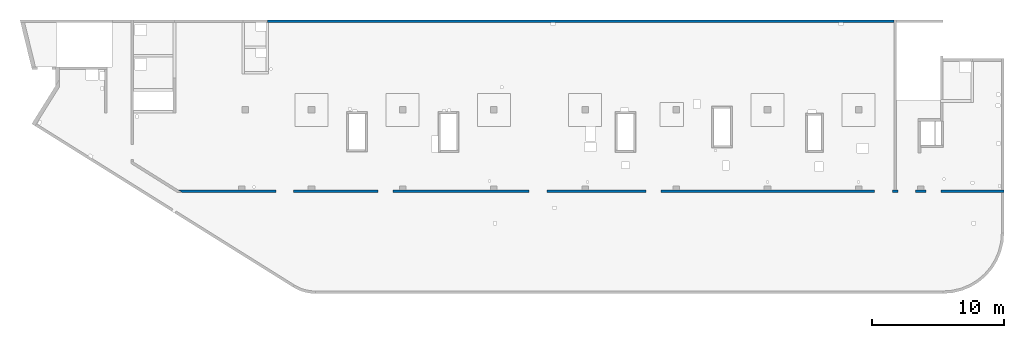
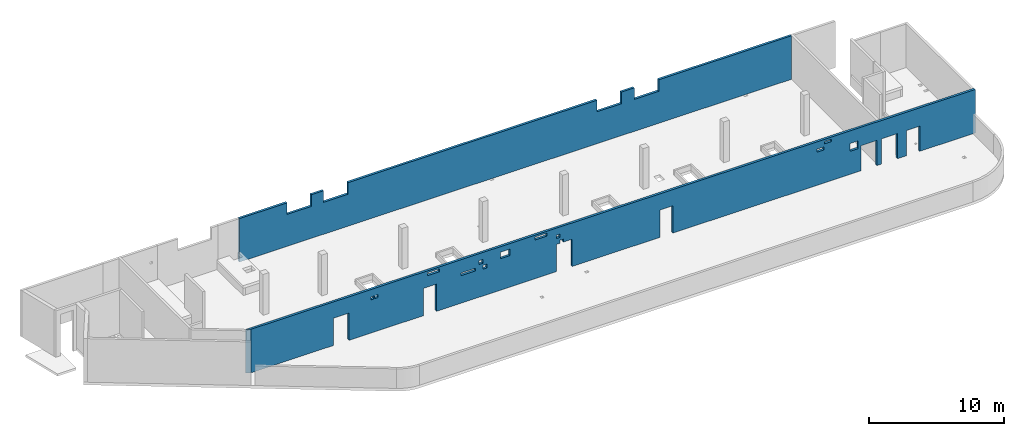
# One storey, part 5 of 6: 2 walls, 24 openings.
"""IFC4 building model written with IfcOpenShell, lengths in millimetres."""

from ifc_helpers import new_model, entity, si_unit, converted_unit, derived_unit, direction, frame, origin, place, context, subcontext, project, spatial, indexed_curve, outline, extrude, polygons, material, type_object, element, save


model = new_model("IFC4")

# Units and contexts
model_context = context("Model", 3, precision=0.01, world=origin(), true_north=direction((6.12303176911189e-17, 1.0)))
plan_context = context("Plan", 3, precision=0.01, world=origin(), true_north=direction((6.12303176911189e-17, 1.0)))
body_context = subcontext(model_context, "Body", "Model", "MODEL_VIEW")
ifc_project = project(units=[si_unit("LENGTHUNIT", "METRE", prefix="MILLI"), si_unit("AREAUNIT", "SQUARE_METRE"), si_unit("VOLUMEUNIT", "CUBIC_METRE"), converted_unit("PLANEANGLEUNIT", "DEGREE", entity("IfcRatioMeasure", 0.0174532925199433), si_unit("PLANEANGLEUNIT", "RADIAN"), dimensions=[0, 0, 0, 0, 0, 0, 0]), si_unit("MASSUNIT", "GRAM", prefix="KILO"), derived_unit("MASSDENSITYUNIT", [(si_unit("MASSUNIT", "GRAM", prefix="KILO"), 1), (si_unit("LENGTHUNIT", "METRE"), -3)]), derived_unit("MOMENTOFINERTIAUNIT", [(si_unit("LENGTHUNIT", "METRE"), 4)]), si_unit("TIMEUNIT", "SECOND"), si_unit("FREQUENCYUNIT", "HERTZ"), si_unit("THERMODYNAMICTEMPERATUREUNIT", "DEGREE_CELSIUS"), derived_unit("THERMALTRANSMITTANCEUNIT", [(si_unit("MASSUNIT", "GRAM", prefix="KILO"), 1), (si_unit("THERMODYNAMICTEMPERATUREUNIT", "KELVIN"), -1), (si_unit("TIMEUNIT", "SECOND"), -3)]), derived_unit("VOLUMETRICFLOWRATEUNIT", [(si_unit("LENGTHUNIT", "METRE"), 3), (si_unit("TIMEUNIT", "SECOND"), -1)]), derived_unit("MASSFLOWRATEUNIT", [(si_unit("MASSUNIT", "GRAM", prefix="KILO"), 1), (si_unit("TIMEUNIT", "SECOND"), -1)]), derived_unit("ROTATIONALFREQUENCYUNIT", [(si_unit("TIMEUNIT", "SECOND"), -1)]), si_unit("ELECTRICCURRENTUNIT", "AMPERE"), si_unit("ELECTRICVOLTAGEUNIT", "VOLT"), si_unit("POWERUNIT", "WATT"), si_unit("FORCEUNIT", "NEWTON", prefix="KILO"), si_unit("ILLUMINANCEUNIT", "LUX"), si_unit("LUMINOUSFLUXUNIT", "LUMEN"), si_unit("LUMINOUSINTENSITYUNIT", "CANDELA"), derived_unit("USERDEFINED", [(si_unit("MASSUNIT", "GRAM", prefix="KILO"), -1), (si_unit("LENGTHUNIT", "METRE"), -2), (si_unit("TIMEUNIT", "SECOND"), 3), (si_unit("LUMINOUSFLUXUNIT", "LUMEN"), 1)]), derived_unit("LINEARVELOCITYUNIT", [(si_unit("LENGTHUNIT", "METRE"), 1), (si_unit("TIMEUNIT", "SECOND"), -1)]), si_unit("PRESSUREUNIT", "PASCAL"), derived_unit("USERDEFINED", [(si_unit("LENGTHUNIT", "METRE"), -2), (si_unit("MASSUNIT", "GRAM", prefix="KILO"), 1), (si_unit("TIMEUNIT", "SECOND"), -2)]), derived_unit("LINEARFORCEUNIT", [(si_unit("MASSUNIT", "GRAM", prefix="KILO"), 1), (si_unit("LENGTHUNIT", "METRE"), 1), (si_unit("TIMEUNIT", "SECOND"), -2), (si_unit("LENGTHUNIT", "METRE"), -1)]), derived_unit("PLANARFORCEUNIT", [(si_unit("MASSUNIT", "GRAM", prefix="KILO"), 1), (si_unit("LENGTHUNIT", "METRE"), 1), (si_unit("TIMEUNIT", "SECOND"), -2), (si_unit("LENGTHUNIT", "METRE"), -2)])], contexts=[model_context, plan_context])

# Site, building, storey
site_placement = place(None, origin())
site = spatial("IfcSite", under=ifc_project, at=site_placement, CompositionType="ELEMENT")
building_placement = place(site_placement, origin())
building = spatial("IfcBuilding", under=site, at=building_placement, CompositionType="ELEMENT")
storey_placement = place(building_placement, frame((0.0, 0.0, 28200.0)))
storey = spatial("IfcBuildingStorey", under=building, at=storey_placement, Name="08", CompositionType="ELEMENT", Elevation=28200.0)

# Wall, openings
ifc_material = material()
wall_type = type_object("IfcWallType", Name=":ADSK_ 25_200", PredefinedType="STANDARD")
wall_1_placement = place(storey_placement, frame((11060.82, 7550.0, -150.0)))
wall_1 = element("IfcWall", 1, at=wall_1_placement, inside=storey, type_object=wall_type, material=ifc_material, Name=":ADSK_ 25_200", ObjectType=":ADSK_ 25_200", PredefinedType="NOTDEFINED", context=body_context, shape_type="Tessellation", body=[
    polygons([(62509.1817957401, -99.9999999999989, 3950.0), (320.073152365613, -100.0, 3950.0), (320.073152365616, -100.0, 0.0), (7409.18261361114, -99.9999999999989, 0.0), (7409.18261361114, -99.9999999999989, 2479.99999999805), (8759.18261361114, -99.9999999999989, 2479.99999999804), (8759.18261361114, -100.000000000001, 0.0), (15129.1826136111, -100.0, 0.0), (15129.1826136111, -100.0, 2479.99999999805), (16259.1826136111, -100.0, 2479.99999999804), (16259.1826136111, -100.0, 0.0), (26559.1826136111, -100.0, 0.0), (26559.1826136111, -100.0, 2479.99999999805), (26859.1826136111, -99.9999999999989, 2479.99999999805), (26859.1826136111, -100.000000000322, 2749.99999999994), (27159.1826136111, -100.000000000321, 2749.99999999994), (27159.1826136111, -100.0, 2479.99999999805), (27909.1826136111, -100.0, 2479.99999999804), (27909.1826136111, -100.0, 0.0), (35429.1826136111, -100.0, 0.0), (35429.1826136111, -100.0, 2479.99999999805), (36559.1826136111, -100.000000000001, 2479.99999999804), (36559.1826136111, -100.000000000001, 0.0), (52719.1826136111, -100.0, 0.0), (52719.1826136111, -100.0, 2279.99999999804), (54069.1826136111, -100.0, 2279.99999999804), (54069.1826136111, -100.0, 0.0), (54469.1826136111, -100.000000000001, 0.0), (54469.1826136111, -99.9999999999989, 2279.99999999804), (55819.1826136111, -100.000000000001, 2279.99999999804), (55819.1826136111, -100.000000000001, 0.0), (56619.1826136111, -100.0, 0.0), (56619.1826136111, -100.0, 2279.99999999804), (57749.1826136111, -100.0, 2279.99999999804), (57749.1826136111, -100.0, 0.0), (62309.1817957401, -100.0, 0.0), (62509.1817957401, -99.9999999999989, 0.0), (62509.1817957401, -100.0, 1770.0), (51759.1826136112, -100.000000000321, 2800.0), (52459.1826136112, -100.000000000321, 2800.0), (52459.1826136112, -100.000000000321, 2100.00000000002), (51759.1826136112, -100.000000000321, 2100.00000000002), (49569.1826136112, -100.000000000321, 3755.0), (50169.1826136112, -100.000000000322, 3755.0), (50169.1826136112, -100.000000000322, 3540.00000000001), (49569.1826136112, -100.000000000321, 3540.00000000001), (48924.1826136112, -100.000000000319, 3284.99999999999), (49524.1826136112, -100.000000000321, 3284.99999999999), (49524.1826136112, -100.000000000321, 3010.0), (48924.1826136112, -100.000000000319, 3010.0), (24729.1826136111, -100.000000000321, 3784.99999999994), (25729.1826136111, -100.000000000321, 3784.99999999994), (25729.1826136111, -100.000000000321, 3509.99999999995), (24729.1826136111, -100.000000000321, 3509.99999999995), (26559.1826136111, -100.000000000321, 3299.99999999994), (26859.1826136111, -100.000000000319, 3299.99999999994), (26859.1826136111, -100.000000000319, 2999.99999999995), (26559.1826136111, -100.000000000321, 2999.99999999995), (21774.1826136111, -100.000000000322, 3450.0), (22574.1826136111, -100.000000000322, 3450.0), (22574.1826136111, -100.000000000322, 2850.00000000001), (21774.1826136111, -100.000000000322, 2850.00000000001), (18359.1826136111, -100.000000000319, 2749.99999999998), (19609.1826136111, -100.000000000321, 2749.99999999998), (19609.1826136111, -100.000000000321, 2500.0), (18359.1826136111, -100.000000000319, 2500.0), (19904.1826136112, -100.000000000319, 3319.99999999999), (20254.1826136111, -100.000000000321, 3319.99999999999), (20254.1826136111, -100.000000000321, 2970.0), (19904.1826136112, -100.000000000319, 2970.0), (20254.1826136111, -100.000000000321, 2779.99999999998), (20604.1826136111, -100.000000000321, 2779.99999999998), (20604.1826136111, -100.000000000321, 2430.0), (20254.1826136111, -100.000000000321, 2430.0), (15504.1826136112, -100.000000000321, 3784.99999999997), (16504.1826136112, -100.000000000321, 3784.99999999997), (16504.1826136112, -100.000000000321, 3509.99999999998), (15504.1826136112, -100.000000000321, 3509.99999999998), (10624.1826136112, -100.000000000321, 3284.99999999995), (10899.1826136112, -100.000000000321, 3284.99999999995), (10899.1826136112, -100.000000000321, 3009.99999999997), (10624.1826136112, -100.000000000321, 3009.99999999997), (10974.1826136112, -100.000000000321, 3284.99999999995), (11249.1826136112, -100.000000000319, 3284.99999999995), (11249.1826136112, -100.000000000319, 3009.99999999997), (10974.1826136112, -100.000000000321, 3009.99999999997), (1.91187300746924e-12, 100.000000000001, 3950.0), (54169.1826136112, 100.0, 3950.0), (54369.1826136112, 100.0, 3950.0), (62309.1817957401, 100.0, 3950.0), (62509.1817957401, 100.0, 3950.0), (62509.1817957401, 100.0, 0.0), (62309.1817957401, 100.0, 0.0), (57749.1826136111, 100.000000000001, 0.0), (57749.1826136111, 100.000000000001, 2279.99999999804), (56619.1826136111, 100.0, 2279.99999999804), (56619.1826136111, 100.0, 0.0), (56459.1826136112, 100.0, 0.0), (55959.1826136112, 100.0, 0.0), (55819.1826136111, 100.0, 0.0), (55819.1826136111, 100.0, 2279.99999999804), (54469.1826136111, 100.0, 2279.99999999804), (54469.1826136111, 100.0, 0.0), (54369.1826136112, 100.0, 0.0), (54169.1826136112, 100.0, 0.0), (54069.1826136111, 100.0, 0.0), (54069.1826136111, 100.0, 2279.99999999804), (52719.1826136111, 100.0, 2279.99999999804), (52719.1826136111, 99.9999999999989, 0.0), (51759.1826136112, 100.0, 0.0), (51259.1826136112, 100.0, 0.0), (44859.1826136112, 100.000000000001, 0.0), (44359.1826136112, 100.0, 0.0), (37959.1826136112, 100.0, 0.0), (37459.1826136112, 100.0, 0.0), (36559.1826136111, 100.0, 0.0), (36559.1826136111, 100.0, 2479.99999999805), (35429.1826136111, 100.0, 2479.99999999805), (35429.1826136111, 100.0, 0.0), (31059.1826136112, 100.0, 0.0), (30559.1826136112, 100.0, 0.0), (27909.1826136111, 100.0, 0.0), (27909.1826136111, 100.0, 2479.99999999805), (27159.1826136111, 100.0, 2479.99999999805), (27159.1826136111, 100.0, 2749.99999999994), (26859.1826136111, 100.0, 2749.99999999994), (26859.1826136111, 100.0, 2479.99999999805), (26559.1826136111, 100.0, 2479.99999999805), (26559.1826136111, 100.0, 0.0), (24159.1826136112, 100.0, 0.0), (23659.1826136112, 100.0, 0.0), (17259.1826136112, 100.0, 0.0), (16759.1826136112, 100.0, 0.0), (16259.1826136111, 100.0, 0.0), (16259.1826136111, 100.0, 2479.99999999805), (15129.1826136111, 99.9999999999989, 2479.99999999805), (15129.1826136111, 99.9999999999989, 0.0), (10359.1826136112, 100.0, 0.0), (9859.18261361118, 100.0, 0.0), (8759.18261361114, 100.0, 0.0), (8759.18261361114, 100.0, 2479.99999999805), (7409.18261361114, 100.0, 2479.99999999805), (7409.18261361115, 100.0, 0.0), (5089.18186898228, 100.0, 0.0), (4589.18186898228, 100.0, 0.0), (-2.53861251127542e-13, 100.000000000001, 0.0), (52459.1826136112, 100.0, 2800.0), (51759.1826136112, 100.0, 2800.0), (51759.1826136112, 100.0, 2100.00000000002), (52459.1826136112, 100.0, 2100.00000000002), (50169.1826136112, 100.0, 3755.0), (49569.1826136112, 100.000000000001, 3755.0), (49569.1826136112, 100.000000000001, 3540.00000000001), (50169.1826136112, 100.0, 3540.00000000001), (49524.1826136112, 100.000000000001, 3284.99999999999), (48924.1826136112, 100.0, 3284.99999999999), (48924.1826136112, 100.0, 3010.0), (49524.1826136112, 100.000000000001, 3010.0), (25729.1826136111, 100.000000000001, 3784.99999999994), (24729.1826136111, 100.000000000001, 3784.99999999994), (24729.1826136111, 100.000000000001, 3509.99999999995), (25729.1826136111, 100.000000000001, 3509.99999999995), (26859.1826136111, 100.0, 3299.99999999994), (26559.1826136111, 100.0, 3299.99999999994), (26559.1826136111, 100.0, 2999.99999999995), (26859.1826136111, 100.0, 2999.99999999995), (22574.1826136111, 100.0, 3450.0), (21774.1826136111, 100.0, 3450.0), (21774.1826136111, 100.0, 2850.00000000001), (22574.1826136111, 100.0, 2850.00000000001), (19609.1826136111, 100.0, 2749.99999999998), (18359.1826136112, 100.000000000001, 2749.99999999998), (18359.1826136112, 100.000000000001, 2500.0), (19609.1826136111, 100.0, 2500.0), (20254.1826136111, 100.0, 3319.99999999999), (19904.1826136111, 100.0, 3319.99999999999), (19904.1826136111, 100.0, 2970.0), (20254.1826136111, 100.0, 2970.0), (20604.1826136111, 99.9999999999989, 2779.99999999998), (20254.1826136111, 100.000000000001, 2779.99999999998), (20254.1826136111, 100.000000000001, 2430.0), (20604.1826136111, 99.9999999999989, 2430.0), (16504.1826136112, 100.000000000001, 3784.99999999997), (15504.1826136112, 100.0, 3784.99999999997), (15504.1826136112, 100.0, 3509.99999999998), (16504.1826136112, 100.000000000001, 3509.99999999998), (10899.1826136112, 100.000000000001, 3284.99999999995), (10624.1826136112, 100.0, 3284.99999999995), (10624.1826136112, 100.0, 3009.99999999997), (10899.1826136112, 100.000000000001, 3009.99999999997), (11249.1826136112, 100.0, 3284.99999999995), (10974.1826136112, 100.000000000001, 3284.99999999995), (10974.1826136112, 100.000000000001, 3009.99999999997), (11249.1826136112, 100.0, 3009.99999999997)], [[[1, 2, 3, 4, 5, 6, 7, 8, 9, 10, 11, 12, 13, 14, 15, 16, 17, 18, 19, 20, 21, 22, 23, 24, 25, 26, 27, 28, 29, 30, 31, 32, 33, 34, 35, 36, 37, 38], [39, 40, 41, 42], [43, 44, 45, 46], [47, 48, 49, 50], [51, 52, 53, 54], [55, 56, 57, 58], [59, 60, 61, 62], [63, 64, 65, 66], [67, 68, 69, 70], [71, 72, 73, 74], [75, 76, 77, 78], [79, 80, 81, 82], [83, 84, 85, 86]], [[87, 88, 89, 90, 91, 92, 93, 94, 95, 96, 97, 98, 99, 100, 101, 102, 103, 104, 105, 106, 107, 108, 109, 110, 111, 112, 113, 114, 115, 116, 117, 118, 119, 120, 121, 122, 123, 124, 125, 126, 127, 128, 129, 130, 131, 132, 133, 134, 135, 136, 137, 138, 139, 140, 141, 142, 143, 144, 145, 146], [147, 148, 149, 150], [151, 152, 153, 154], [155, 156, 157, 158], [159, 160, 161, 162], [163, 164, 165, 166], [167, 168, 169, 170], [171, 172, 173, 174], [175, 176, 177, 178], [179, 180, 181, 182], [183, 184, 185, 186], [187, 188, 189, 190], [191, 192, 193, 194]], [[3, 146, 145, 144, 143, 4]], [[2, 1, 91, 90, 89, 88, 87]], [[3, 2, 87, 146]], [[37, 92, 91, 1, 38]], [[29, 102, 101, 30]], [[30, 101, 100, 31]], [[102, 29, 28, 103]], [[5, 142, 141, 6]], [[6, 141, 140, 7]], [[142, 5, 4, 143]], [[9, 136, 135, 10]], [[10, 135, 134, 11]], [[136, 9, 8, 137]], [[123, 18, 17, 124]], [[18, 123, 122, 19]], [[128, 13, 12, 129]], [[21, 118, 117, 22]], [[22, 117, 116, 23]], [[118, 21, 20, 119]], [[25, 108, 107, 26]], [[26, 107, 106, 27]], [[108, 25, 24, 109]], [[33, 96, 95, 34]], [[34, 95, 94, 35]], [[96, 33, 32, 97]], [[40, 39, 148, 147]], [[40, 147, 150, 41]], [[41, 150, 149, 42]], [[148, 39, 42, 149]], [[44, 43, 152, 151]], [[44, 151, 154, 45]], [[45, 154, 153, 46]], [[152, 43, 46, 153]], [[48, 47, 156, 155]], [[48, 155, 158, 49]], [[49, 158, 157, 50]], [[156, 47, 50, 157]], [[52, 51, 160, 159]], [[52, 159, 162, 53]], [[53, 162, 161, 54]], [[160, 51, 54, 161]], [[56, 55, 164, 163]], [[56, 163, 166, 57]], [[57, 166, 165, 58]], [[164, 55, 58, 165]], [[125, 16, 15, 126]], [[16, 125, 124, 17]], [[126, 15, 14, 127]], [[60, 59, 168, 167]], [[60, 167, 170, 61]], [[61, 170, 169, 62]], [[168, 59, 62, 169]], [[64, 63, 172, 171]], [[64, 171, 174, 65]], [[65, 174, 173, 66]], [[172, 63, 66, 173]], [[68, 67, 176, 175]], [[68, 175, 178, 69]], [[69, 178, 177, 70]], [[176, 67, 70, 177]], [[179, 72, 71, 180]], [[72, 179, 182, 73]], [[73, 182, 181, 74]], [[180, 71, 74, 181]], [[76, 75, 184, 183]], [[76, 183, 186, 77]], [[77, 186, 185, 78]], [[184, 75, 78, 185]], [[80, 79, 188, 187]], [[80, 187, 190, 81]], [[81, 190, 189, 82]], [[188, 79, 82, 189]], [[84, 83, 192, 191]], [[84, 191, 194, 85]], [[85, 194, 193, 86]], [[192, 83, 86, 193]], [[13, 128, 127, 14]], [[7, 140, 139, 138, 137, 8]], [[11, 134, 133, 132, 131, 130, 129, 12]], [[19, 122, 121, 120, 119, 20]], [[23, 116, 115, 114, 113, 112, 111, 110, 109, 24]], [[27, 106, 105, 104, 103, 28]], [[31, 100, 99, 98, 97, 32]], [[92, 37, 36, 35, 94, 93]]], closed=True),
])
placement_1 = place(wall_1_placement, frame((-11060.82, -7550.0, 150.0)))
element("IfcOpeningElement", 2, at=placement_1, cuts=wall_1, Name=":ADSK_ 25_200", PredefinedType="OPENING", context=body_context, shape_type="SweptSolid", body=[
    extrude(outline(indexed_curve([(-675.000000000003, -1239.99999999902), (674.999999999998, -1239.99999999902), (674.999999999998, 1239.99999999902), (-675.000000000003, 1239.99999999902), (-675.000000000003, -1239.99999999902)], self_intersect=False)), frame((19145.0, 7350.0, 1090.0), z_axis=(0.0, 1.0, 0.0), x_axis=(1.0, 0.0, 0.0)), (0.0, 0.0, 1.0), 400.000000001942),
])
element("IfcOpeningElement", 3, at=placement_1, cuts=wall_1, Name=":ADSK_ 25_200", PredefinedType="OPENING", context=body_context, shape_type="SweptSolid", body=[
    extrude(outline(indexed_curve([(-564.999999999997, -1239.99999999902), (565.000000000001, -1239.99999999902), (565.000000000001, 1239.99999999902), (-564.999999999997, 1239.99999999902), (-564.999999999997, -1239.99999999902)], self_intersect=False)), frame((26755.0, 7350.0, 1090.0), z_axis=(0.0, 1.0, 0.0), x_axis=(1.0, 0.0, 0.0)), (0.0, 0.0, 1.0), 400.000000001942),
])
placement_2 = place(wall_1_placement, frame((-11060.82, -7550.0, -4050.0)))
element("IfcOpeningElement", 4, at=placement_2, cuts=wall_1, Name=":ADSK_ 25_200", PredefinedType="OPENING", context=body_context, shape_type="SweptSolid", body=[
    extrude(outline(indexed_curve([(-675.000000000003, -1239.99999999902), (674.999999999998, -1239.99999999902), (674.999999999998, 1239.99999999902), (-675.000000000003, 1239.99999999902), (-675.000000000003, -1239.99999999902)], self_intersect=False)), frame((38295.0, 7350.0, 5290.0), z_axis=(0.0, 1.0, 0.0), x_axis=(1.0, 0.0, 0.0)), (0.0, 0.0, 1.0), 400.000000001943),
])
element("IfcOpeningElement", 5, at=placement_2, cuts=wall_1, Name=":ADSK_ 25_200", PredefinedType="OPENING", context=body_context, shape_type="SweptSolid", body=[
    extrude(outline(indexed_curve([(-565.000000000001, -1239.99999999902), (565.000000000001, -1239.99999999902), (565.000000000001, 1239.99999999902), (-565.000000000001, 1239.99999999902), (-565.000000000001, -1239.99999999902)], self_intersect=False)), frame((47055.0, 7350.0, 5290.0), z_axis=(0.0, 1.0, 0.0), x_axis=(1.0, 0.0, 0.0)), (0.0, 0.0, 1.0), 400.000000001943),
])
element("IfcOpeningElement", 6, at=placement_1, cuts=wall_1, Name=":ADSK_ 25_200", PredefinedType="OPENING", context=body_context, shape_type="SweptSolid", body=[
    extrude(outline(indexed_curve([(-675.000000000003, -1139.99999999902), (674.999999999994, -1139.99999999902), (674.999999999994, 1139.99999999902), (-675.000000000003, 1139.99999999902), (-675.000000000003, -1139.99999999902)], self_intersect=False)), frame((64455.0, 7350.0, 990.0), z_axis=(0.0, 1.0, 0.0), x_axis=(1.0, 0.0, 0.0)), (0.0, 0.0, 1.0), 400.000000001943),
])
element("IfcOpeningElement", 7, at=placement_1, cuts=wall_1, Name=":ADSK_ 25_200", PredefinedType="OPENING", context=body_context, shape_type="SweptSolid", body=[
    extrude(outline(indexed_curve([(-675.000000000003, -1139.99999999902), (674.999999999994, -1139.99999999902), (674.999999999994, 1139.99999999902), (-675.000000000003, 1139.99999999902), (-675.000000000003, -1139.99999999902)], self_intersect=False)), frame((66205.0, 7350.0, 990.0), z_axis=(0.0, 1.0, 0.0), x_axis=(1.0, 0.0, 0.0)), (0.0, 0.0, 1.0), 400.000000001942),
])
element("IfcOpeningElement", 8, at=placement_2, cuts=wall_1, Name=":ADSK_ 25_200", PredefinedType="OPENING", context=body_context, shape_type="SweptSolid", body=[
    extrude(outline(indexed_curve([(-565.000000000001, -1139.99999999902), (565.000000000001, -1139.99999999902), (565.000000000001, 1139.99999999902), (-565.000000000001, 1139.99999999902), (-565.000000000001, -1139.99999999902)], self_intersect=False)), frame((68245.0, 7350.0, 5190.0), z_axis=(0.0, 1.0, 0.0), x_axis=(1.0, 0.0, 0.0)), (0.0, 0.0, 1.0), 400.000000001942),
])
element("IfcOpeningElement", 9, at=placement_1, cuts=wall_1, Name=":ADSK_ 25_200", PredefinedType="OPENING", context=body_context, shape_type="SweptSolid", body=[
    extrude(outline(indexed_curve([(-150.000000000001, -134.999999999991), (150.000000000001, -134.999999999991), (150.000000000001, 134.999999999995), (-150.000000000001, 134.999999999995), (-150.000000000001, -134.999999999991)], self_intersect=False)), frame((38070.0, 7450.0, 2465.0), z_axis=(0.0, 1.0, 0.0), x_axis=(1.0, 0.0, 0.0)), (0.0, 0.0, 1.0), 200.000000000962),
])
element("IfcOpeningElement", 10, at=placement_1, cuts=wall_1, Name=":ADSK_ 25_200", PredefinedType="OPENING", context=body_context, shape_type="SweptSolid", body=[
    extrude(outline(indexed_curve([(-174.999999999999, -174.999999999991), (174.999999999999, -174.999999999991), (174.999999999999, 174.999999999995), (-174.999999999999, 174.999999999995), (-174.999999999999, -174.999999999991)], self_intersect=False)), frame((31140.0, 7450.0, 2995.0), z_axis=(0.0, 1.0, 0.0), x_axis=(1.0, 0.0, 0.0)), (0.0, 0.0, 1.0), 200.000000000962),
])
element("IfcOpeningElement", 11, at=placement_1, cuts=wall_1, Name=":ADSK_ 25_200", PredefinedType="OPENING", context=body_context, shape_type="SweptSolid", body=[
    extrude(outline(indexed_curve([(-175.000000000004, -174.999999999991), (174.999999999995, -174.999999999991), (174.999999999995, 174.999999999995), (-175.000000000004, 174.999999999995), (-175.000000000004, -174.999999999991)], self_intersect=False)), frame((31490.0, 7450.0, 2455.0), z_axis=(0.0, 1.0, 0.0), x_axis=(1.0, 0.0, 0.0)), (0.0, 0.0, 1.0), 200.000000000962),
])
element("IfcOpeningElement", 12, at=placement_1, cuts=wall_1, Name=":ADSK_ 25_200", PredefinedType="OPENING", context=body_context, shape_type="SweptSolid", body=[
    extrude(outline(indexed_curve([(-150.000000000001, -149.999999999992), (150.000000000001, -149.999999999992), (150.000000000001, 149.999999999992), (-150.000000000001, 149.999999999992), (-150.000000000001, -149.999999999992)], self_intersect=False)), frame((37770.0, 7450.0, 3000.0), z_axis=(0.0, 1.0, 0.0), x_axis=(1.0, 0.0, 0.0)), (0.0, 0.0, 1.0), 200.000000000962),
])
element("IfcOpeningElement", 13, at=placement_1, cuts=wall_1, Name=":ADSK_ 25_200", PredefinedType="OPENING", context=body_context, shape_type="SweptSolid", body=[
    extrude(outline(indexed_curve([(-349.999999999998, -349.999999999994), (349.999999999998, -349.999999999994), (349.999999999998, 349.99999999999), (-349.999999999998, 349.99999999999), (-349.999999999998, -349.999999999994)], self_intersect=False)), frame((63170.0, 7450.0, 2300.0), z_axis=(0.0, 1.0, 0.0), x_axis=(1.0, 0.0, 0.0)), (0.0, 0.0, 1.0), 200.000000000962),
])
element("IfcOpeningElement", 14, at=placement_1, cuts=wall_1, Name=":ADSK_ 25_200", PredefinedType="OPENING", context=body_context, shape_type="SweptSolid", body=[
    extrude(outline(indexed_curve([(-300.000000000001, -107.499999999993), (300.000000000001, -107.499999999993), (300.000000000001, 107.499999999993), (-300.000000000001, 107.499999999993), (-300.000000000001, -107.499999999993)], self_intersect=False)), frame((60930.0, 7450.0, 3497.5), z_axis=(0.0, 1.0, 0.0), x_axis=(1.0, 0.0, 0.0)), (0.0, 0.0, 1.0), 200.000000000962),
])
element("IfcOpeningElement", 15, at=placement_1, cuts=wall_1, Name=":ADSK_ 25_200", PredefinedType="OPENING", context=body_context, shape_type="SweptSolid", body=[
    extrude(outline(indexed_curve([(-300.000000000001, -137.49999999999), (300.000000000001, -137.49999999999), (300.000000000001, 137.499999999995), (-300.000000000001, 137.499999999995), (-300.000000000001, -137.49999999999)], self_intersect=False)), frame((60285.0, 7450.0, 2997.5), z_axis=(0.0, 1.0, 0.0), x_axis=(1.0, 0.0, 0.0)), (0.0, 0.0, 1.0), 200.000000000962),
])
element("IfcOpeningElement", 16, at=placement_1, cuts=wall_1, Name=":ADSK_ 25_200", PredefinedType="OPENING", context=body_context, shape_type="SweptSolid", body=[
    extrude(outline(indexed_curve([(-499.999999999999, -137.499999999995), (499.999999999999, -137.499999999995), (499.999999999999, 137.49999999999), (-499.999999999999, 137.49999999999), (-499.999999999999, -137.499999999995)], self_intersect=False)), frame((36290.0, 7450.0, 3497.5), z_axis=(0.0, 1.0, 0.0), x_axis=(1.0, 0.0, 0.0)), (0.0, 0.0, 1.0), 200.000000000962),
])
element("IfcOpeningElement", 17, at=placement_1, cuts=wall_1, Name=":ADSK_ 25_200", PredefinedType="OPENING", context=body_context, shape_type="SweptSolid", body=[
    extrude(outline(indexed_curve([(-400.0, -299.999999999992), (400.0, -299.999999999992), (400.0, 299.999999999992), (-400.0, 299.999999999992), (-400.0, -299.999999999992)], self_intersect=False)), frame((33235.0, 7450.0, 3000.0), z_axis=(0.0, 1.0, 0.0), x_axis=(1.0, 0.0, 0.0)), (0.0, 0.0, 1.0), 200.000000000962),
])
element("IfcOpeningElement", 18, at=placement_1, cuts=wall_1, Name=":ADSK_ 25_200", PredefinedType="OPENING", context=body_context, shape_type="SweptSolid", body=[
    extrude(outline(indexed_curve([(-625.000000000005, -124.999999999998), (624.999999999996, -124.999999999998), (624.999999999996, 124.999999999989), (-625.000000000005, 124.999999999989), (-625.000000000005, -124.999999999998)], self_intersect=False)), frame((30045.0, 7450.0, 2475.0), z_axis=(0.0, 1.0, 0.0), x_axis=(1.0, 0.0, 0.0)), (0.0, 0.0, 1.0), 200.000000000962),
])
element("IfcOpeningElement", 19, at=placement_1, cuts=wall_1, Name=":ADSK_ 25_200", PredefinedType="OPENING", context=body_context, shape_type="SweptSolid", body=[
    extrude(outline(indexed_curve([(-499.999999999999, -137.49999999999), (499.999999999999, -137.49999999999), (499.999999999999, 137.499999999995), (-499.999999999999, 137.499999999995), (-499.999999999999, -137.49999999999)], self_intersect=False)), frame((27065.0, 7450.0, 3497.5), z_axis=(0.0, 1.0, 0.0), x_axis=(1.0, 0.0, 0.0)), (0.0, 0.0, 1.0), 200.000000000962),
])
element("IfcOpeningElement", 20, at=placement_1, cuts=wall_1, Name=":ADSK_ 25_200", PredefinedType="OPENING", context=body_context, shape_type="SweptSolid", body=[
    extrude(outline(indexed_curve([(-137.499999999999, -137.49999999999), (137.499999999999, -137.49999999999), (137.499999999999, 137.499999999995), (-137.499999999999, 137.499999999995), (-137.499999999999, -137.49999999999)], self_intersect=False)), frame((21822.5, 7450.0, 2997.5), z_axis=(0.0, 1.0, 0.0), x_axis=(1.0, 0.0, 0.0)), (0.0, 0.0, 1.0), 200.000000000962),
])
element("IfcOpeningElement", 21, at=placement_1, cuts=wall_1, Name=":ADSK_ 25_200", PredefinedType="OPENING", context=body_context, shape_type="SweptSolid", body=[
    extrude(outline(indexed_curve([(-137.499999999999, -137.49999999999), (137.499999999999, -137.49999999999), (137.499999999999, 137.499999999995), (-137.499999999999, 137.499999999995), (-137.499999999999, -137.49999999999)], self_intersect=False)), frame((22172.5, 7450.0, 2997.5), z_axis=(0.0, 1.0, 0.0), x_axis=(1.0, 0.0, 0.0)), (0.0, 0.0, 1.0), 200.000000000962),
])

wall_2_placement = place(storey_placement, frame((65230.0, 20400.0, -150.0), z_axis=(0.0, 0.0, 1.0), x_axis=(-1.0, 0.0, 0.0)))
wall_2 = element("IfcWall", 22, at=wall_2_placement, inside=storey, type_object=wall_type, material=ifc_material, Name=":ADSK_ 25_200", ObjectType=":ADSK_ 25_200", PredefinedType="NOTDEFINED", context=body_context, shape_type="Tessellation", body=[
    polygons([(-2.29534734415479e-12, -100.000000000003, 0.0), (47405.0, -100.000000000003, 0.0), (47405.0, -100.000000000003, 3950.0), (43325.0000000001, -100.000000000008, 3950.0), (43325.0000000001, -100.000000000328, 2900.00000000001), (41225.0000000001, -100.000000000324, 2900.00000000001), (41225.0000000001, -100.000000000003, 3950.0), (40175.0000000001, -100.000000000008, 3950.0), (40175.0000000001, -100.000000000324, 2900.00000000001), (38075.0000000001, -100.000000000324, 2900.00000000001), (38075.0000000001, -100.000000000003, 3950.0), (16710.0000000001, -100.000000000008, 3950.0), (16710.0000000001, -100.000000000328, 2899.99999999994), (14610.0000000001, -100.000000000324, 2899.99999999994), (14610.0000000001, -100.000000000003, 3950.0), (13510.0000000001, -100.000000000003, 3950.0), (13510.0000000001, -100.000000000324, 2899.99999999993), (11410.0000000001, -100.000000000328, 2899.99999999993), (11410.0000000001, -100.000000000008, 3950.0), (-2.29534734415479e-12, -100.000000000003, 3950.0), (47405.0, 99.9999999999989, 0.0), (47305.0, 99.9999999999946, 0.0), (25930.0, 99.9999999999946, 0.0), (25630.0, 99.9999999999989, 0.0), (4160.00000000003, 99.9999999999989, 0.0), (3860.00000000001, 99.9999999999989, 0.0), (-2.94908538678751e-12, 99.9999999999989, 0.0), (-2.94908538678751e-12, 99.9999999999989, 3950.0), (11410.0000000001, 99.9999999999946, 3950.0), (11410.0000000001, 99.9999999999946, 2899.99999999993), (13510.0000000001, 99.9999999999989, 2899.99999999993), (13510.0000000001, 99.9999999999989, 3950.0), (14610.0000000001, 99.9999999999989, 3950.0), (14610.0000000001, 99.9999999999989, 2899.99999999994), (16710.0000000001, 99.9999999999946, 2899.99999999994), (16710.0000000001, 99.9999999999946, 3950.0), (25630.0, 99.9999999999989, 3950.0), (25930.0, 99.9999999999946, 3950.0), (38075.0000000001, 99.9999999999989, 3950.0), (38075.0000000001, 99.9999999999989, 2900.00000000001), (40175.0000000001, 99.9999999999989, 2900.00000000001), (40175.0000000001, 99.9999999999989, 3950.0), (41225.0000000001, 99.9999999999989, 3950.0), (41225.0000000001, 99.9999999999989, 2900.00000000001), (43325.0000000001, 99.9999999999946, 2900.00000000001), (43325.0000000001, 99.9999999999946, 3950.0), (47405.0, 99.9999999999989, 3950.0)], [[[1, 2, 3, 4, 5, 6, 7, 8, 9, 10, 11, 12, 13, 14, 15, 16, 17, 18, 19, 20]], [[21, 22, 23, 24, 25, 26, 27, 28, 29, 30, 31, 32, 33, 34, 35, 36, 37, 38, 39, 40, 41, 42, 43, 44, 45, 46, 47]], [[2, 1, 27, 26, 25, 24, 23, 22, 21]], [[3, 47, 46, 4]], [[1, 20, 28, 27]], [[2, 21, 47, 3]], [[41, 9, 8, 42]], [[9, 41, 40, 10]], [[10, 40, 39, 11]], [[45, 5, 4, 46]], [[5, 45, 44, 6]], [[6, 44, 43, 7]], [[35, 13, 12, 36]], [[13, 35, 34, 14]], [[14, 34, 33, 15]], [[31, 17, 16, 32]], [[17, 31, 30, 18]], [[18, 30, 29, 19]], [[11, 39, 38, 37, 36, 12]], [[15, 33, 32, 16]], [[42, 8, 7, 43]], [[28, 20, 19, 29]]], closed=True),
])
placement_3 = place(wall_2_placement, frame((65230.0, 20400.0, 150.0), z_axis=(0.0, 0.0, 1.0), x_axis=(-1.0, 0.0, 0.0)))
element("IfcOpeningElement", 23, at=placement_3, cuts=wall_2, Name=":ADSK_ 25_200", PredefinedType="OPENING", context=body_context, shape_type="SweptSolid", body=[
    extrude(outline(indexed_curve([(-1050.0, -524.999999999993), (1050.0, -524.999999999993), (1050.0, 524.999999999993), (-1050.0, 524.999999999993), (-1050.0, -524.999999999993)], self_intersect=False)), frame((26105.0, 20500.0, 3275.0), z_axis=(0.0, -1.0, 0.0), x_axis=(-1.0, 0.0, 0.0)), (0.0, 0.0, 1.0), 200.000000000959),
])
element("IfcOpeningElement", 24, at=placement_3, cuts=wall_2, Name=":ADSK_ 25_200", PredefinedType="OPENING", context=body_context, shape_type="SweptSolid", body=[
    extrude(outline(indexed_curve([(-1050.0, -524.999999999993), (1050.0, -524.999999999993), (1050.0, 524.999999999993), (-1050.0, 524.999999999993), (-1050.0, -524.999999999993)], self_intersect=False)), frame((22955.0, 20500.0, 3275.0), z_axis=(0.0, -1.0, 0.0), x_axis=(-1.0, 0.0, 0.0)), (0.0, 0.0, 1.0), 200.000000000959),
])
element("IfcOpeningElement", 25, at=placement_3, cuts=wall_2, Name=":ADSK_ 25_200", PredefinedType="OPENING", context=body_context, shape_type="SweptSolid", body=[
    extrude(outline(indexed_curve([(-1050.0, -524.999999999993), (1050.0, -524.999999999993), (1050.0, 524.999999999993), (-1050.0, 524.999999999993), (-1050.0, -524.999999999993)], self_intersect=False)), frame((49570.0, 20500.0, 3275.0), z_axis=(0.0, -1.0, 0.0), x_axis=(-1.0, 0.0, 0.0)), (0.0, 0.0, 1.0), 200.000000000959),
])
element("IfcOpeningElement", 26, at=placement_3, cuts=wall_2, Name=":ADSK_ 25_200", PredefinedType="OPENING", context=body_context, shape_type="SweptSolid", body=[
    extrude(outline(indexed_curve([(-1050.0, -524.999999999993), (1050.0, -524.999999999993), (1050.0, 524.999999999993), (-1050.0, 524.999999999993), (-1050.0, -524.999999999993)], self_intersect=False)), frame((52770.0, 20500.0, 3275.0), z_axis=(0.0, -1.0, 0.0), x_axis=(-1.0, 0.0, 0.0)), (0.0, 0.0, 1.0), 200.000000000959),
])

save(model, "model.ifc")
